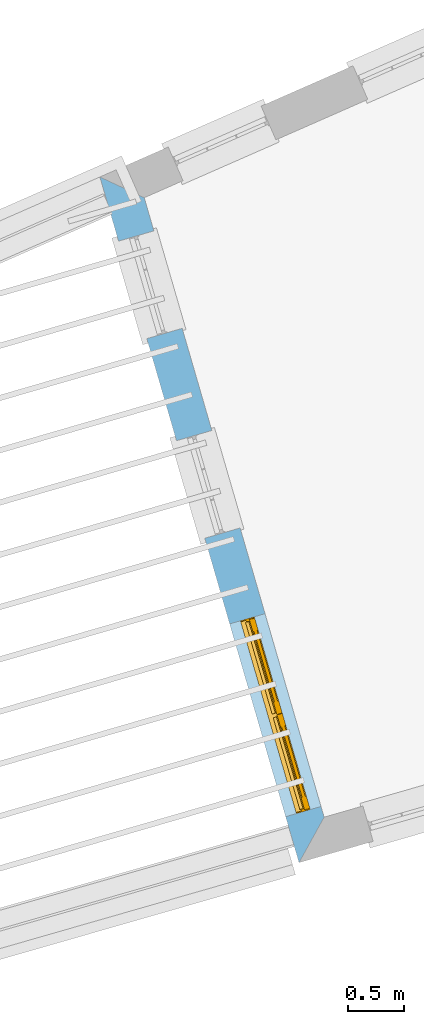
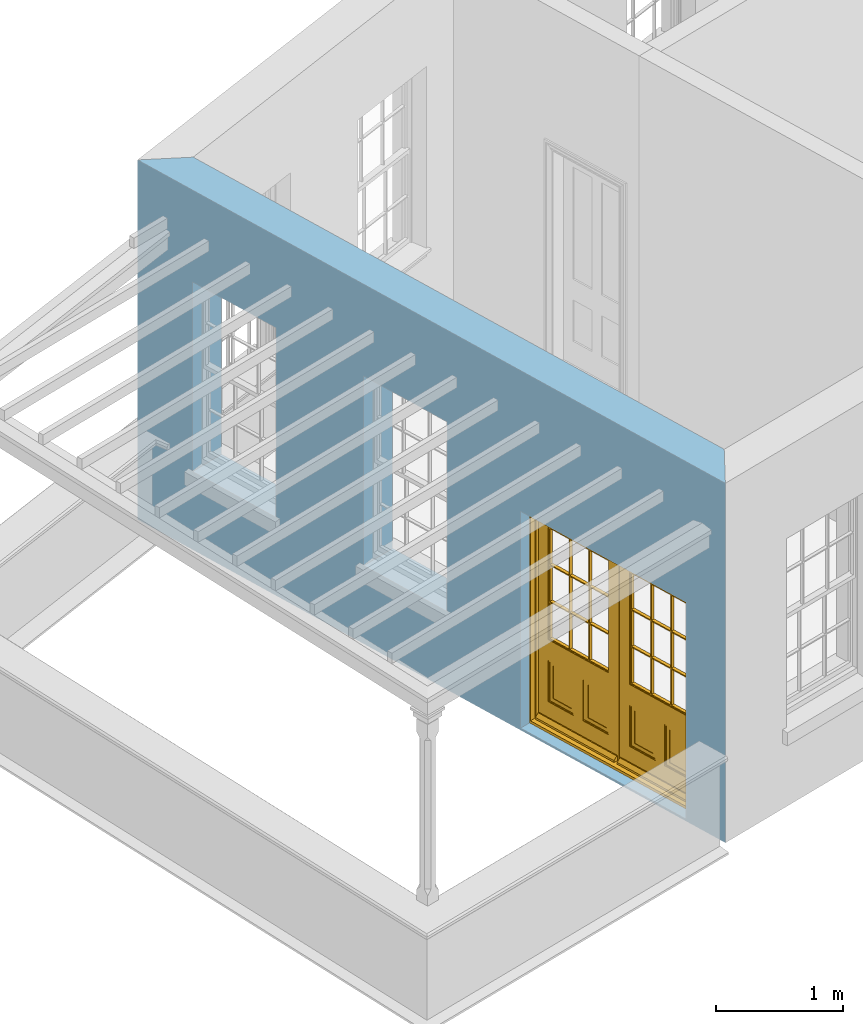
# One storey, part 3 of 11: 1 door, 3 openings, plus 1 element that does not belong to this part.
"""IFC2X3 building model written with IfcOpenShell, lengths in metres."""

import ifcopenshell
import ifcopenshell.guid

model = None  # the IFC model being written
_history = None  # IfcOwnerHistory: only IFC2X3 demands one
_inside = {}  # id of a spatial element -> (the spatial element, [elements in it])
_under = {}  # id of a project, library or spatial element -> (it, [spatial elements below it])
_declared = {}  # id of a project -> (the project, [libraries it declares])
_typed = {}  # id of a type object -> (the type object, [elements of that type])
_made_of = {}  # id of a material, layer set ... -> (it, [elements and type objects made of it])


def new_model(schema):
    """Start an empty IFC model of exactly this schema.

    Asked for "IFC4X3", IfcOpenShell would pick the latest addendum, in which some entities
    have other attributes; the version numbers below select the first issue.
    IFC2X3 requires an IfcOwnerHistory on every rooted entity: one is made here for all.
    """
    global model, _history
    if schema == "IFC4X3":
        model = ifcopenshell.file(schema_version=(4, 3, 0, 0))
    else:
        model = ifcopenshell.file(schema=schema)
    _inside.clear()
    _under.clear()
    _declared.clear()
    _typed.clear()
    _made_of.clear()
    _history = None
    if model.schema == "IFC2X3":
        org = make("IfcOrganization", Name="unknown")
        user = make(
            "IfcPersonAndOrganization",
            ThePerson=make("IfcPerson", FamilyName="unknown"),
            TheOrganization=org,
        )
        app = make(
            "IfcApplication",
            ApplicationDeveloper=org,
            Version="unknown",
            ApplicationFullName="unknown",
            ApplicationIdentifier="unknown",
        )
        _history = make(
            "IfcOwnerHistory",
            OwningUser=user,
            OwningApplication=app,
            ChangeAction="ADDED",
            CreationDate=0,
        )
    return model


def make(cls, **values):
    """One entity of the class cls with the attributes given. An attribute that is None is left unset."""
    return model.create_entity(
        cls, **{name: value for name, value in values.items() if value is not None}
    )


def rooted(cls, **values):
    """An entity with a GlobalId (a new one), such as an element, a storey or a relation."""
    return make(cls, GlobalId=ifcopenshell.guid.new(), OwnerHistory=_history, **values)


def si_unit(unit_type, name, prefix=None):
    """IfcSIUnit, for example si_unit("LENGTHUNIT", "METRE", prefix="MILLI")."""
    return make("IfcSIUnit", UnitType=unit_type, Prefix=prefix, Name=name)


def assignment(units):
    """IfcUnitAssignment: the units of a project."""
    return None if units is None else make("IfcUnitAssignment", Units=units)


def point(xyz):
    """IfcCartesianPoint."""
    return None if xyz is None else make("IfcCartesianPoint", Coordinates=xyz)


def direction(xyz):
    """IfcDirection."""
    return None if xyz is None else make("IfcDirection", DirectionRatios=xyz)


def frame(location, z_axis=None, x_axis=None):
    """IfcAxis2Placement3D, a coordinate frame: its origin and axes. An axis left out is left unset."""
    return make(
        "IfcAxis2Placement3D",
        Location=point(location),
        Axis=direction(z_axis),
        RefDirection=direction(x_axis),
    )


def origin():
    """The frame at (0, 0, 0) with its axes left unset."""
    return frame((0.0, 0.0, 0.0))


def place(relative_to, where):
    """IfcLocalPlacement: puts the frame where relative to a parent placement (None: the world)."""
    return make(
        "IfcLocalPlacement", PlacementRelTo=relative_to, RelativePlacement=where
    )


def context(
    kind, dimensions, precision=None, world=None, true_north=None, identifier=None
):
    """IfcGeometricRepresentationContext, for example the 3D "Model" context."""
    return make(
        "IfcGeometricRepresentationContext",
        ContextIdentifier=identifier,
        ContextType=kind,
        CoordinateSpaceDimension=dimensions,
        Precision=precision,
        WorldCoordinateSystem=world,
        TrueNorth=true_north,
    )


def subcontext(parent, identifier, kind, view, scale=None):
    """IfcGeometricRepresentationSubContext, for example "Body" below "Model"."""
    return make(
        "IfcGeometricRepresentationSubContext",
        ContextIdentifier=identifier,
        ContextType=kind,
        ParentContext=parent,
        TargetScale=scale,
        TargetView=view,
    )


def project(units=None, contexts=None):
    """IfcProject with its units and contexts."""
    return rooted(
        "IfcProject",
        Name="project",
        RepresentationContexts=contexts,
        UnitsInContext=assignment(units),
    )


def spatial(cls, under=None, at=None, **own):
    """A site, building, storey or space (cls), placed at a placement, below another one or the project."""
    s = rooted(cls, ObjectPlacement=at, **own)
    if under is not None:
        _under.setdefault(under.id(), (under, []))[1].append(s)
    return s


def polyline(points):
    """IfcPolyline through the points."""
    return make("IfcPolyline", Points=[point(p) for p in points])


def outline(outer, holes=None, kind="AREA"):
    """IfcArbitraryClosedProfileDef: a profile drawn as a closed curve; with holes, ...WithVoids."""
    if holes is None:
        return make("IfcArbitraryClosedProfileDef", ProfileType=kind, OuterCurve=outer)
    return make(
        "IfcArbitraryProfileDefWithVoids",
        ProfileType=kind,
        OuterCurve=outer,
        InnerCurves=holes,
    )


def extrude(swept, where, along, depth):
    """IfcExtrudedAreaSolid: the profile swept, set in the frame where, extruded along a direction by depth."""
    return make(
        "IfcExtrudedAreaSolid",
        SweptArea=swept,
        Position=where,
        ExtrudedDirection=direction(along),
        Depth=depth,
    )


def faces_of(points, faces, orient=None, outer=None):
    """IfcFace entities. A face is a list of loops; a loop is a list of indices into points, from 0.

    orient and outer hold one flag for each loop. By default every Orientation is true, the
    first loop of a face is its IfcFaceOuterBound and the others are IfcFaceBound.
    """
    made = []
    for i, loops in enumerate(faces):
        bounds = []
        for j, loop in enumerate(loops):
            is_outer = j == 0 if outer is None else outer[i][j]
            bounds.append(
                make(
                    "IfcFaceOuterBound" if is_outer else "IfcFaceBound",
                    Bound=make("IfcPolyLoop", Polygon=[points[k] for k in loop]),
                    Orientation=True if orient is None else orient[i][j],
                )
            )
        made.append(make("IfcFace", Bounds=bounds))
    return made


def faceted_brep(points, faces, orient=None, outer=None, voids=None):
    """IfcFacetedBrep: a solid bounded by flat faces; with voids (closed shells), ...WithVoids."""
    shared = [point(p) for p in points]
    hull = make("IfcClosedShell", CfsFaces=faces_of(shared, faces, orient, outer))
    if voids is None:
        return make("IfcFacetedBrep", Outer=hull)
    return make(
        "IfcFacetedBrepWithVoids",
        Outer=hull,
        Voids=[
            make(cls, CfsFaces=faces_of(shared, fs, o, b)) for cls, fs, o, b in voids
        ],
    )


def shape(context_of_items, identifier, shape_type, items):
    """IfcShapeRepresentation: the items that make up one representation, for example the "Body"."""
    return make(
        "IfcShapeRepresentation",
        ContextOfItems=context_of_items,
        RepresentationIdentifier=identifier,
        RepresentationType=shape_type,
        Items=items,
    )


def material(Name=None, Category=None):
    """IfcMaterial."""
    return make("IfcMaterial", Name=Name, Category=Category)


def layer(
    of_material, thickness, ventilated=None, Name=None, Category=None, Priority=None
):
    """IfcMaterialLayer: one layer of a wall or slab, of a material (None: an air gap)."""
    return make(
        "IfcMaterialLayer",
        Material=of_material,
        LayerThickness=thickness,
        IsVentilated=ventilated,
        Name=Name,
        Category=Category,
        Priority=Priority,
    )


def layer_set(layers, Name=None):
    """IfcMaterialLayerSet."""
    return make("IfcMaterialLayerSet", MaterialLayers=layers, LayerSetName=Name)


def layer_usage(for_layer_set, set_direction, sense, offset, extent=None):
    """IfcMaterialLayerSetUsage: how a layer set lies in its element."""
    return make(
        "IfcMaterialLayerSetUsage",
        ForLayerSet=for_layer_set,
        LayerSetDirection=set_direction,
        DirectionSense=sense,
        OffsetFromReferenceLine=offset,
        ReferenceExtent=extent,
    )


def made_of(thing, what):
    """Note that an element or type object is made of a material, layer set ...; save() writes the relation."""
    if what is not None:
        _made_of.setdefault(what.id(), (what, []))[1].append(thing)
    return thing


def element(
    cls,
    number,
    at=None,
    inside=None,
    cuts=None,
    type_object=None,
    material=None,
    context=None,
    identifier="Body",
    shape_type=None,
    held_by="IfcProductDefinitionShape",
    body=None,
    shapes=None,
    **own,
):
    """One element of the class cls, such as IfcWall. Its Tag is "e" and its number.

    at: its placement. inside: the storey or other place that contains it. cuts: it is an
    opening in that element (IfcRelVoidsElement). A single representation is given by context,
    identifier, shape_type and body (its items); several are given by shapes. held_by: the class
    of the entity that holds the representations. save() writes the other relations.
    """
    e = rooted(cls, Tag="e%d" % number, ObjectPlacement=at, **own)
    if body is not None:
        shapes = [shape(context, identifier, shape_type, body)]
    if shapes is not None:
        e.Representation = make(held_by, Representations=shapes)
    if inside is not None:
        _inside.setdefault(inside.id(), (inside, []))[1].append(e)
    if cuts is not None:
        rooted(
            "IfcRelVoidsElement", RelatingBuildingElement=cuts, RelatedOpeningElement=e
        )
    if type_object is not None:
        _typed.setdefault(type_object.id(), (type_object, []))[1].append(e)
    return made_of(e, material)


def fill(opening, filler):
    """IfcRelFillsElement: the door or window that sits in an opening."""
    return rooted(
        "IfcRelFillsElement",
        RelatingOpeningElement=opening,
        RelatedBuildingElement=filler,
    )


def aggregate(whole, parts):
    """IfcRelAggregates: a whole, such as a stair, and the parts it consists of."""
    return rooted("IfcRelAggregates", RelatingObject=whole, RelatedObjects=parts)


def save(model, path):
    """Write the relations noted so far, then the file.

    IfcRelAggregates (storeys below a building ...), IfcRelContainedInSpatialStructure (elements
    in a storey), IfcRelDefinesByType, IfcRelAssociatesMaterial and IfcRelDeclares: one each for
    every whole, place, type object, material and project.
    """
    for whole, parts in _under.values():
        aggregate(whole, parts)
    for where, things in _inside.values():
        rooted(
            "IfcRelContainedInSpatialStructure",
            RelatedElements=things,
            RelatingStructure=where,
        )
    for kind, things in _typed.values():
        rooted("IfcRelDefinesByType", RelatedObjects=things, RelatingType=kind)
    for what, things in _made_of.values():
        rooted("IfcRelAssociatesMaterial", RelatedObjects=things, RelatingMaterial=what)
    for by, libraries in _declared.values():
        rooted("IfcRelDeclares", RelatingContext=by, RelatedDefinitions=libraries)
    model.write(path)


model = new_model("IFC2X3")

# Units and contexts
model_context = context("Model", 3, world=origin())
body_context = subcontext(model_context, "Body", "Model", "MODEL_VIEW")
ifc_project = project(units=[si_unit("PLANEANGLEUNIT", "RADIAN"), si_unit("MASSUNIT", "GRAM", prefix="KILO"), si_unit("FORCEUNIT", "NEWTON", prefix="KILO"), si_unit("LENGTHUNIT", "METRE")], contexts=[model_context])

# Site, building, storey
site_placement = place(None, origin())
site = spatial("IfcSite", under=ifc_project, at=site_placement, CompositionType="ELEMENT")
building_placement = place(None, origin())
building = spatial("IfcBuilding", under=site, at=building_placement, Name="Building plot-15", CompositionType="ELEMENT")
storey_placement = place(None, frame((0.0, 0.0, 7.6)))
storey = spatial("IfcBuildingStorey", under=building, at=storey_placement, Name="Floor 1", CompositionType="ELEMENT", Elevation=7.6)

# Wall, openings, door
ifc_material = material(Name="Masonry")
ifc_layer = layer(ifc_material, 0.33, ventilated=False)
ifc_layer_set = layer_set([ifc_layer], Name="My Wall")
ifc_layer_usage = layer_usage(ifc_layer_set, "AXIS2", "NEGATIVE", 0.08)
wall_placement = place(storey_placement, origin())
wall = element("IfcWallStandardCase", 1, at=wall_placement, inside=storey, material=ifc_layer_usage, Name="exterior", context=body_context, shape_type="SweptSolid", body=[
    extrude(outline(polyline([(85.6873979783644, 56.0228656256528), (85.2898260322487, 56.2086132391335), (87.0751399602823, 50.0606585087336), (87.3002897494389, 50.4686684405552), (85.6873979783644, 56.0228656256528)])), origin(), (0.0, 0.0, 1.0), 3.45),
])
opening_1_placement = place(storey_placement, frame((0.0, 0.0, 0.75)))
element("IfcOpeningElement", 2, at=opening_1_placement, cuts=wall, Name="Opening", ObjectType="Opening", context=body_context, shape_type="SweptSolid", body=[
    extrude(outline(polyline([(85.4569058524119, 55.6332527075221), (85.7106786931988, 54.7593537744188), (86.0275870975109, 54.8513812881108), (85.773814256724, 55.725280221214), (85.4569058524119, 55.6332527075221)])), origin(), (0.0, 0.0, 1.0), 1.82),
])
opening_2_placement = place(storey_placement, frame((0.0, 0.0, 0.75)))
element("IfcOpeningElement", 3, at=opening_2_placement, cuts=wall, Name="Opening", ObjectType="Opening", context=body_context, shape_type="SweptSolid", body=[
    extrude(outline(polyline([(85.9765909320635, 53.8436512858375), (86.2303637728504, 52.9697523527342), (86.5472721771625, 53.0617798664262), (86.2934993363756, 53.9356787995294), (85.9765909320635, 53.8436512858375)])), origin(), (0.0, 0.0, 1.0), 1.82),
])
opening_3_placement = place(storey_placement, frame((0.0, 0.0, 0.0199999999999996)))
opening_3 = element("IfcOpeningElement", 4, at=opening_3_placement, cuts=wall, Name="Opening", ObjectType="Opening", context=body_context, shape_type="SweptSolid", body=[
    extrude(outline(polyline([(86.45346077574, 52.2014895544017), (86.9554290322415, 50.4728982581536), (87.2723374365537, 50.5649257718456), (86.7703691800521, 52.2935170680937), (86.45346077574, 52.2014895544017)])), origin(), (0.0, 0.0, 1.0), 2.08),
])
door_placement = place(storey_placement, frame((86.6935429002189, 52.2712073678047, 0.0199999999999996), z_axis=(0.0, 0.0, 1.0), x_axis=(0.501968256501584, -1.72859129624812, 0.0)))
door = element("IfcDoor", 5, at=door_placement, inside=storey, Name="living outside door", OverallHeight=2.08, OverallWidth=1.8, context=body_context, shape_type="Brep", held_by="IfcProductRepresentation", body=[
    faceted_brep([(0.545, -0.055, 0.265), (0.745, -0.055, 0.265), (0.745, -0.05, 0.265), (0.545, -0.05, 0.265), (0.745, -0.05, 0.58), (0.545, -0.05, 0.58), (0.545, -0.055, 0.58), (0.515, -0.06, 0.235), (0.775, -0.06, 0.235), (0.745, -0.055, 0.58), (0.515, -0.06, 0.61), (0.515, -0.065, 0.235), (0.775, -0.065, 0.235), (0.775, -0.06, 0.61), (0.515, -0.065, 0.61), (0.785, -0.065, 0.225), (0.505, -0.065, 0.225), (0.775, -0.065, 0.61), (0.505, -0.065, 0.62), (0.785, -0.065, 0.62), (0.505, -0.07, 0.225), (0.785, -0.07, 0.225), (0.505, -0.07, 0.62), (0.785, -0.07, 0.62), (0.883, -0.07, 0.075), (0.898, -0.07, 0.075), (0.405, -0.07, 0.62), (0.405, -0.07, 0.225), (0.027, -0.07, 0.075), (0.785, -0.07, 0.82), (0.125, -0.07, 0.82), (0.405, -0.065, 0.62), (0.405, -0.065, 0.225), (0.898, -0.07, 2.068), (0.027, -0.08, 0.075), (0.883, -0.08, 0.075), (0.125, -0.07, 0.225), (0.012, -0.07, 0.075), (0.785, -0.06, 0.82), (0.125, -0.06, 0.82), (0.125, -0.07, 0.62), (0.125, -0.065, 0.62), (0.395, -0.065, 0.61), (0.395, -0.065, 0.235), (0.125, -0.065, 0.225), (0.785, -0.07, 1.895), (0.027, -0.11, 0.045), (0.883, -0.11, 0.045), (0.558333, -0.06, 0.83), (0.351667, -0.06, 0.83), (0.125, -0.07, 1.895), (0.125, -0.06, 1.895), (0.785, -0.06, 1.895), (0.012, -0.07, 2.068), (0.135, -0.065, 0.61), (0.395, -0.06, 0.61), (0.395, -0.06, 0.235), (0.135, -0.065, 0.235), (0.027, -0.11, 0.027), (0.883, -0.11, 0.027), (0.568333, -0.06, 0.83), (0.558333, -0.03, 0.83), (0.351667, -0.03, 0.83), (0.341667, -0.06, 0.83), (0.135, -0.06, 1.185), (0.135, -0.06, 1.53), (0.775, -0.06, 1.53), (0.775, -0.06, 1.185), (0.135, -0.06, 0.61), (0.365, -0.055, 0.58), (0.365, -0.055, 0.265), (0.135, -0.06, 0.235), (0.568333, -0.06, 1.175), (0.558333, -0.06, 1.175), (0.775, -0.06, 0.83), (0.558333, -0.03, 1.175), (0.785, -0.03, 0.82), (0.125, -0.03, 0.82), (0.351667, -0.03, 1.175), (0.351667, -0.06, 1.175), (0.341667, -0.06, 1.175), (0.135, -0.06, 0.83), (0.135, -0.06, 1.175), (0.135, -0.03, 1.185), (0.135, -0.03, 1.53), (0.135, -0.06, 1.54), (0.351667, -0.06, 1.885), (0.558333, -0.06, 1.885), (0.775, -0.03, 1.53), (0.775, -0.03, 1.185), (0.775, -0.06, 1.175), (0.775, -0.06, 1.54), (0.165, -0.055, 0.58), (0.365, -0.05, 0.58), (0.365, -0.05, 0.265), (0.165, -0.055, 0.265), (0.568333, -0.03, 0.83), (0.568333, -0.03, 1.175), (0.568333, -0.06, 1.185), (0.558333, -0.06, 1.185), (0.775, -0.03, 0.83), (0.785, -0.02, 0.82), (0.125, -0.02, 0.82), (0.341667, -0.03, 0.83), (0.341667, -0.03, 1.175), (0.351667, -0.06, 1.185), (0.341667, -0.06, 1.185), (0.135, -0.03, 0.83), (0.341667, -0.03, 1.185), (0.125, -0.03, 1.895), (0.341667, -0.03, 1.53), (0.341667, -0.06, 1.53), (0.135, -0.06, 1.885), (0.341667, -0.06, 1.54), (0.341667, -0.06, 1.885), (0.558333, -0.03, 1.885), (0.351667, -0.03, 1.885), (0.568333, -0.06, 1.885), (0.785, -0.03, 1.895), (0.568333, -0.03, 1.185), (0.568333, -0.06, 1.53), (0.568333, -0.03, 1.53), (0.568333, -0.06, 1.54), (0.775, -0.06, 1.885), (0.165, -0.05, 0.58), (0.165, -0.05, 0.265), (0.775, -0.03, 1.175), (0.558333, -0.06, 1.53), (0.351667, -0.03, 1.185), (0.558333, -0.03, 1.185), (0.505, -0.02, 0.62), (0.405, -0.02, 0.62), (0.125, -0.02, 1.895), (0.785, -0.02, 1.895), (0.351667, -0.06, 1.53), (0.135, -0.03, 1.175), (0.135, -0.03, 1.54), (0.341667, -0.03, 1.54), (0.135, -0.03, 1.885), (0.351667, -0.06, 1.54), (0.558333, -0.03, 1.54), (0.558333, -0.06, 1.54), (0.351667, -0.03, 1.54), (0.775, -0.03, 1.54), (0.568333, -0.03, 1.54), (0.775, -0.03, 1.885), (0.558333, -0.03, 1.53), (0.405, -0.02, 0.225), (0.505, -0.02, 0.225), (0.125, -0.02, 0.62), (0.785, -0.02, 0.62), (0.012, -0.02, 2.068), (0.898, -0.02, 2.068), (0.351667, -0.03, 1.53), (0.341667, -0.03, 1.885), (0.568333, -0.03, 1.885), (0.405, -0.025, 0.225), (0.405, -0.025, 0.62), (0.505, -0.025, 0.62), (0.505, -0.025, 0.225), (0.898, -0.02, 0.027), (0.012, -0.02, 0.027), (0.125, -0.025, 0.62), (0.785, -0.025, 0.62), (0.395, -0.025, 0.235), (0.395, -0.025, 0.61), (0.125, -0.02, 0.225), (0.125, -0.025, 0.225), (0.515, -0.025, 0.61), (0.515, -0.025, 0.235), (0.785, -0.02, 0.225), (0.785, -0.025, 0.225), (0.135, -0.025, 0.61), (0.775, -0.025, 0.61), (0.135, -0.025, 0.235), (0.395, -0.03, 0.235), (0.395, -0.03, 0.61), (0.515, -0.03, 0.61), (0.515, -0.03, 0.235), (0.775, -0.025, 0.235), (0.135, -0.03, 0.61), (0.775, -0.03, 0.61), (0.135, -0.03, 0.235), (0.365, -0.035, 0.265), (0.365, -0.035, 0.58), (0.545, -0.035, 0.58), (0.545, -0.035, 0.265), (0.775, -0.03, 0.235), (0.165, -0.035, 0.58), (0.745, -0.035, 0.58), (0.165, -0.035, 0.265), (0.365, -0.04, 0.58), (0.365, -0.04, 0.265), (0.545, -0.04, 0.58), (0.545, -0.04, 0.265), (0.745, -0.035, 0.265), (0.165, -0.04, 0.58), (0.745, -0.04, 0.58), (0.165, -0.04, 0.265), (0.745, -0.04, 0.265), (1.775, -0.072, 0.025), (0.025, -0.072, 0.025), (0.025, -0.1, 0.025), (1.775, -0.1, 0.025), (1.79, -0.02, 0.025), (0.01, -0.02, 0.025), (1.79, -0.072, 0.025), (1.8, -0.02, 0.0), (0.0, -0.02, 0.0), (0.01, -0.072, 0.025), (1.79, -0.072, 2.07), (1.79, -0.02, 2.07), (1.775, -0.072, 2.055), (1.8, -0.02, 2.08), (0.01, -0.02, 2.07), (0.0, -0.02, 2.08), (0.01, -0.072, 2.07), (0.025, -0.072, 2.055), (0.0, -0.15, 2.08), (1.8, -0.15, 2.08), (0.01, -0.15, 2.07), (1.79, -0.15, 2.07), (0.01, -0.1, 2.07), (1.79, -0.1, 2.07), (0.0, -0.15, 0.0), (1.8, -0.15, 0.0), (0.01, -0.15, 0.025), (1.79, -0.15, 0.025), (0.01, -0.1, 0.025), (0.025, -0.1, 2.055), (1.79, -0.1, 0.025), (1.775, -0.1, 2.055), (0.898, -0.07, 0.027), (0.012, -0.07, 0.027), (0.883, -0.07, 0.027), (0.027, -0.07, 0.027), (1.435, -0.055, 0.265), (1.635, -0.055, 0.265), (1.635, -0.05, 0.265), (1.435, -0.05, 0.265), (1.635, -0.05, 0.58), (1.435, -0.05, 0.58), (1.435, -0.055, 0.58), (1.405, -0.06, 0.235), (1.665, -0.06, 0.235), (1.635, -0.055, 0.58), (1.405, -0.06, 0.61), (1.405, -0.065, 0.235), (1.665, -0.065, 0.235), (1.665, -0.06, 0.61), (1.405, -0.065, 0.61), (1.675, -0.065, 0.225), (1.395, -0.065, 0.225), (1.665, -0.065, 0.61), (1.395, -0.065, 0.62), (1.675, -0.065, 0.62), (1.395, -0.07, 0.225), (1.675, -0.07, 0.225), (1.395, -0.07, 0.62), (1.675, -0.07, 0.62), (1.773, -0.07, 0.075), (1.788, -0.07, 0.075), (1.295, -0.07, 0.62), (1.295, -0.07, 0.225), (0.917, -0.07, 0.075), (1.675, -0.07, 0.82), (1.015, -0.07, 0.82), (1.295, -0.065, 0.62), (1.295, -0.065, 0.225), (1.788, -0.07, 2.068), (0.917, -0.08, 0.075), (1.773, -0.08, 0.075), (1.015, -0.07, 0.225), (0.902, -0.07, 0.075), (1.675, -0.06, 0.82), (1.015, -0.06, 0.82), (1.015, -0.07, 0.62), (1.015, -0.065, 0.62), (1.285, -0.065, 0.61), (1.285, -0.065, 0.235), (1.015, -0.065, 0.225), (1.675, -0.07, 1.895), (0.917, -0.11, 0.045), (1.773, -0.11, 0.045), (1.448333, -0.06, 0.83), (1.241667, -0.06, 0.83), (1.015, -0.07, 1.895), (1.015, -0.06, 1.895), (1.675, -0.06, 1.895), (0.902, -0.07, 2.068), (1.025, -0.065, 0.61), (1.285, -0.06, 0.61), (1.285, -0.06, 0.235), (1.025, -0.065, 0.235), (0.917, -0.11, 0.027), (1.773, -0.11, 0.027), (1.458333, -0.06, 0.83), (1.448333, -0.03, 0.83), (1.241667, -0.03, 0.83), (1.231667, -0.06, 0.83), (1.025, -0.06, 1.185), (1.025, -0.06, 1.53), (1.665, -0.06, 1.53), (1.665, -0.06, 1.185), (1.025, -0.06, 0.61), (1.255, -0.055, 0.58), (1.255, -0.055, 0.265), (1.025, -0.06, 0.235), (1.458333, -0.06, 1.175), (1.448333, -0.06, 1.175), (1.665, -0.06, 0.83), (1.448333, -0.03, 1.175), (1.675, -0.03, 0.82), (1.015, -0.03, 0.82), (1.241667, -0.03, 1.175), (1.241667, -0.06, 1.175), (1.231667, -0.06, 1.175), (1.025, -0.06, 0.83), (1.025, -0.06, 1.175), (1.025, -0.03, 1.185), (1.025, -0.03, 1.53), (1.025, -0.06, 1.54), (1.241667, -0.06, 1.885), (1.448333, -0.06, 1.885), (1.665, -0.03, 1.53), (1.665, -0.03, 1.185), (1.665, -0.06, 1.175), (1.665, -0.06, 1.54), (1.055, -0.055, 0.58), (1.255, -0.05, 0.58), (1.255, -0.05, 0.265), (1.055, -0.055, 0.265), (1.458333, -0.03, 0.83), (1.458333, -0.03, 1.175), (1.458333, -0.06, 1.185), (1.448333, -0.06, 1.185), (1.665, -0.03, 0.83), (1.675, -0.02, 0.82), (1.015, -0.02, 0.82), (1.231667, -0.03, 0.83), (1.231667, -0.03, 1.175), (1.241667, -0.06, 1.185), (1.231667, -0.06, 1.185), (1.025, -0.03, 0.83), (1.231667, -0.03, 1.185), (1.015, -0.03, 1.895), (1.231667, -0.03, 1.53), (1.231667, -0.06, 1.53), (1.025, -0.06, 1.885), (1.231667, -0.06, 1.54), (1.231667, -0.06, 1.885), (1.448333, -0.03, 1.885), (1.241667, -0.03, 1.885), (1.458333, -0.06, 1.885), (1.675, -0.03, 1.895), (1.458333, -0.03, 1.185), (1.458333, -0.06, 1.53), (1.458333, -0.03, 1.53), (1.458333, -0.06, 1.54), (1.665, -0.06, 1.885), (1.055, -0.05, 0.58), (1.055, -0.05, 0.265), (1.665, -0.03, 1.175), (1.448333, -0.06, 1.53), (1.241667, -0.03, 1.185), (1.448333, -0.03, 1.185), (1.395, -0.02, 0.62), (1.295, -0.02, 0.62), (1.015, -0.02, 1.895), (1.675, -0.02, 1.895), (1.241667, -0.06, 1.53), (1.025, -0.03, 1.175), (1.025, -0.03, 1.54), (1.231667, -0.03, 1.54), (1.025, -0.03, 1.885), (1.241667, -0.06, 1.54), (1.448333, -0.03, 1.54), (1.448333, -0.06, 1.54), (1.241667, -0.03, 1.54), (1.665, -0.03, 1.54), (1.458333, -0.03, 1.54), (1.665, -0.03, 1.885), (1.448333, -0.03, 1.53), (1.295, -0.02, 0.225), (1.395, -0.02, 0.225), (1.015, -0.02, 0.62), (1.675, -0.02, 0.62), (0.902, -0.02, 2.068), (1.788, -0.02, 2.068), (1.241667, -0.03, 1.53), (1.231667, -0.03, 1.885), (1.458333, -0.03, 1.885), (1.295, -0.025, 0.225), (1.295, -0.025, 0.62), (1.395, -0.025, 0.62), (1.395, -0.025, 0.225), (1.788, -0.02, 0.027), (0.902, -0.02, 0.027), (1.015, -0.025, 0.62), (1.675, -0.025, 0.62), (1.285, -0.025, 0.235), (1.285, -0.025, 0.61), (1.015, -0.02, 0.225), (1.015, -0.025, 0.225), (1.405, -0.025, 0.61), (1.405, -0.025, 0.235), (1.675, -0.02, 0.225), (1.675, -0.025, 0.225), (1.025, -0.025, 0.61), (1.665, -0.025, 0.61), (1.025, -0.025, 0.235), (1.285, -0.03, 0.235), (1.285, -0.03, 0.61), (1.405, -0.03, 0.61), (1.405, -0.03, 0.235), (1.665, -0.025, 0.235), (1.025, -0.03, 0.61), (1.665, -0.03, 0.61), (1.025, -0.03, 0.235), (1.255, -0.035, 0.265), (1.255, -0.035, 0.58), (1.435, -0.035, 0.58), (1.435, -0.035, 0.265), (1.665, -0.03, 0.235), (1.055, -0.035, 0.58), (1.635, -0.035, 0.58), (1.055, -0.035, 0.265), (1.255, -0.04, 0.58), (1.255, -0.04, 0.265), (1.435, -0.04, 0.58), (1.435, -0.04, 0.265), (1.635, -0.035, 0.265), (1.055, -0.04, 0.58), (1.635, -0.04, 0.58), (1.055, -0.04, 0.265), (1.635, -0.04, 0.265), (1.788, -0.07, 0.027), (0.902, -0.07, 0.027), (1.773, -0.07, 0.027), (0.917, -0.07, 0.027)], [[[0, 1, 2, 3]], [[2, 4, 5, 3]], [[0, 3, 5, 6]], [[1, 0, 7, 8]], [[9, 4, 2, 1]], [[9, 6, 5, 4]], [[0, 6, 10, 7]], [[8, 7, 11, 12]], [[8, 13, 9, 1]], [[13, 10, 6, 9]], [[7, 10, 14, 11]], [[15, 12, 11, 16]], [[12, 17, 13, 8]], [[17, 14, 10, 13]], [[18, 16, 11, 14]], [[15, 19, 17, 12]], [[15, 16, 20, 21]], [[14, 17, 19, 18]], [[16, 18, 22, 20]], [[21, 23, 19, 15]], [[24, 25, 21, 20]], [[23, 22, 18, 19]], [[20, 22, 26, 27]], [[23, 21, 25]], [[28, 24, 20, 27]], [[22, 23, 29]], [[29, 30, 26, 22]], [[27, 26, 31, 32]], [[23, 25, 33, 29]], [[34, 35, 24, 28]], [[28, 27, 36, 37]], [[38, 39, 30, 29]], [[26, 30, 40]], [[26, 40, 41, 31]], [[42, 43, 32, 31]], [[32, 44, 36, 27]], [[33, 45, 29]], [[46, 47, 35, 34]], [[36, 40, 37]], [[39, 38, 48, 49]], [[50, 30, 39, 51]], [[29, 45, 52, 38]], [[53, 37, 40, 30]], [[44, 41, 40, 36]], [[31, 41, 54, 42]], [[43, 42, 55, 56]], [[57, 44, 32, 43]], [[50, 45, 33, 53]], [[47, 46, 58, 59]], [[60, 48, 38]], [[49, 48, 61, 62]], [[49, 63, 39]], [[50, 53, 30]], [[51, 39, 64, 65]], [[45, 50, 51, 52]], [[66, 67, 38, 52]], [[57, 54, 41, 44]], [[42, 54, 68, 55]], [[56, 55, 69, 70]], [[56, 71, 57, 43]], [[60, 72, 73, 48]], [[60, 38, 74]], [[48, 73, 75, 61]], [[76, 77, 62, 61]], [[62, 78, 79, 49]], [[49, 79, 80, 63]], [[63, 81, 39]], [[82, 64, 39]], [[65, 64, 83, 84]], [[85, 51, 65]], [[52, 51, 86, 87]], [[88, 89, 67, 66]], [[90, 38, 67]], [[91, 66, 52]], [[71, 68, 54, 57]], [[55, 68, 92, 69]], [[69, 93, 94, 70]], [[70, 95, 71, 56]], [[96, 97, 72, 60]], [[73, 72, 98, 99]], [[74, 38, 90]], [[100, 96, 60, 74]], [[75, 73, 79, 78]], [[61, 75, 97, 96]], [[101, 102, 77, 76]], [[77, 103, 62]], [[96, 76, 61]], [[103, 104, 78, 62]], [[80, 79, 105, 106]], [[63, 80, 104, 103]], [[81, 63, 103, 107]], [[81, 82, 39]], [[106, 64, 82, 80]], [[106, 108, 83, 64]], [[84, 83, 77, 109]], [[110, 111, 65, 84]], [[112, 51, 85]], [[113, 85, 65, 111]], [[114, 86, 51]], [[115, 87, 86, 116]], [[117, 52, 87]], [[118, 76, 89, 88]], [[119, 98, 67, 89]], [[120, 121, 88, 66]], [[67, 98, 72, 90]], [[91, 122, 120, 66]], [[91, 52, 123]], [[95, 92, 68, 71]], [[69, 92, 124, 93]], [[94, 93, 124, 125]], [[94, 125, 95, 70]], [[72, 97, 126, 90]], [[127, 99, 98, 120]], [[99, 105, 79, 73]], [[74, 90, 126, 100]], [[96, 100, 76]], [[128, 129, 75, 78]], [[97, 75, 129, 119]], [[130, 131, 102, 101]], [[109, 77, 102, 132]], [[133, 101, 76, 118]], [[77, 107, 103]], [[78, 104, 108, 128]], [[111, 106, 105, 134]], [[104, 80, 82, 135]], [[107, 135, 82, 81]], [[110, 108, 106, 111]], [[104, 135, 83, 108]], [[83, 135, 77]], [[136, 84, 109]], [[110, 84, 136, 137]], [[114, 51, 112]], [[85, 136, 138, 112]], [[113, 137, 136, 85]], [[111, 134, 139, 113]], [[86, 114, 113, 139]], [[140, 141, 87, 115]], [[139, 142, 116, 86]], [[109, 118, 115, 116]], [[117, 123, 52]], [[117, 87, 141, 122]], [[126, 89, 76]], [[143, 118, 88]], [[120, 98, 119, 121]], [[119, 89, 126, 97]], [[144, 143, 88, 121]], [[144, 122, 91, 143]], [[127, 120, 122, 141]], [[143, 91, 123, 145]], [[124, 92, 95, 125]], [[146, 129, 99, 127]], [[99, 129, 128, 105]], [[100, 126, 76]], [[121, 119, 129, 146]], [[147, 131, 130, 148]], [[131, 149, 102]], [[130, 101, 150]], [[102, 151, 132]], [[118, 109, 132, 133]], [[101, 133, 152]], [[107, 77, 135]], [[153, 128, 108, 110]], [[134, 105, 128, 153]], [[109, 138, 136]], [[153, 110, 137, 142]], [[154, 114, 112, 138]], [[137, 113, 114, 154]], [[141, 139, 134, 127]], [[141, 140, 142, 139]], [[144, 140, 115, 155]], [[142, 137, 154, 116]], [[155, 115, 118]], [[116, 154, 109]], [[117, 155, 145, 123]], [[122, 144, 155, 117]], [[143, 145, 118]], [[121, 146, 140, 144]], [[146, 127, 134, 153]], [[156, 157, 131, 147]], [[148, 130, 158, 159]], [[148, 160, 161, 147]], [[157, 162, 149, 131]], [[161, 151, 102, 149]], [[101, 152, 160, 150]], [[163, 158, 130, 150]], [[151, 152, 133, 132]], [[154, 138, 109]], [[142, 140, 146, 153]], [[145, 155, 118]], [[157, 156, 164, 165]], [[147, 166, 167, 156]], [[168, 169, 159, 158]], [[170, 148, 159, 171]], [[148, 170, 160]], [[166, 147, 161]], [[172, 162, 157, 165]], [[166, 149, 162, 167]], [[166, 161, 149]], [[150, 160, 170]], [[163, 173, 168, 158]], [[171, 163, 150, 170]], [[174, 164, 156, 167]], [[175, 176, 165, 164]], [[169, 168, 177, 178]], [[171, 159, 169, 179]], [[167, 162, 172, 174]], [[176, 180, 172, 165]], [[179, 173, 163, 171]], [[181, 177, 168, 173]], [[164, 174, 182, 175]], [[183, 184, 176, 175]], [[178, 177, 185, 186]], [[179, 169, 178, 187]], [[174, 172, 180, 182]], [[184, 188, 180, 176]], [[187, 181, 173, 179]], [[189, 185, 177, 181]], [[175, 182, 190, 183]], [[191, 184, 183, 192]], [[185, 193, 194, 186]], [[187, 178, 186, 195]], [[182, 180, 188, 190]], [[191, 196, 188, 184]], [[195, 189, 181, 187]], [[197, 193, 185, 189]], [[183, 190, 198, 192]], [[198, 196, 191, 192]], [[194, 193, 197, 199]], [[195, 186, 194, 199]], [[188, 196, 198, 190]], [[197, 189, 195, 199]], [[200, 201, 202, 203]], [[201, 200, 204, 205]], [[206, 204, 200]], [[204, 207, 208, 205]], [[209, 201, 205]], [[210, 211, 204, 206]], [[206, 200, 212, 210]], [[211, 213, 207, 204]], [[214, 205, 208, 215]], [[216, 217, 201, 209]], [[205, 214, 216, 209]], [[216, 214, 211, 210]], [[210, 212, 217, 216]], [[214, 215, 213, 211]], [[218, 219, 213, 215]], [[219, 218, 220, 221]], [[221, 220, 222, 223]], [[215, 208, 224, 218]], [[225, 224, 208, 207]], [[224, 226, 220, 218]], [[224, 225, 227, 226]], [[219, 225, 207, 213]], [[228, 222, 220, 226]], [[219, 221, 227, 225]], [[226, 227, 203, 202]], [[202, 229, 222, 228]], [[228, 226, 202]], [[227, 221, 223, 230]], [[230, 203, 227]], [[217, 229, 202, 201]], [[231, 223, 222, 229]], [[230, 223, 231, 203]], [[231, 229, 217, 212]], [[212, 200, 203, 231]], [[33, 152, 151, 53]], [[25, 160, 152, 33]], [[161, 37, 53, 151]], [[232, 160, 25]], [[161, 233, 37]], [[160, 232, 234]], [[24, 234, 232, 25]], [[233, 161, 235]], [[37, 233, 235, 28]], [[161, 160, 234, 235]], [[35, 47, 234, 24]], [[28, 235, 46, 34]], [[58, 235, 234, 59]], [[59, 234, 47]], [[58, 46, 235]], [[236, 237, 238, 239]], [[238, 240, 241, 239]], [[236, 239, 241, 242]], [[237, 236, 243, 244]], [[245, 240, 238, 237]], [[245, 242, 241, 240]], [[236, 242, 246, 243]], [[244, 243, 247, 248]], [[244, 249, 245, 237]], [[249, 246, 242, 245]], [[243, 246, 250, 247]], [[251, 248, 247, 252]], [[248, 253, 249, 244]], [[253, 250, 246, 249]], [[254, 252, 247, 250]], [[251, 255, 253, 248]], [[251, 252, 256, 257]], [[250, 253, 255, 254]], [[252, 254, 258, 256]], [[257, 259, 255, 251]], [[260, 261, 257, 256]], [[259, 258, 254, 255]], [[256, 258, 262, 263]], [[259, 257, 261]], [[264, 260, 256, 263]], [[258, 259, 265]], [[265, 266, 262, 258]], [[263, 262, 267, 268]], [[259, 261, 269, 265]], [[270, 271, 260, 264]], [[264, 263, 272, 273]], [[274, 275, 266, 265]], [[262, 266, 276]], [[262, 276, 277, 267]], [[278, 279, 268, 267]], [[268, 280, 272, 263]], [[269, 281, 265]], [[282, 283, 271, 270]], [[272, 276, 273]], [[275, 274, 284, 285]], [[286, 266, 275, 287]], [[265, 281, 288, 274]], [[289, 273, 276, 266]], [[280, 277, 276, 272]], [[267, 277, 290, 278]], [[279, 278, 291, 292]], [[293, 280, 268, 279]], [[286, 281, 269, 289]], [[283, 282, 294, 295]], [[296, 284, 274]], [[285, 284, 297, 298]], [[285, 299, 275]], [[286, 289, 266]], [[287, 275, 300, 301]], [[281, 286, 287, 288]], [[302, 303, 274, 288]], [[293, 290, 277, 280]], [[278, 290, 304, 291]], [[292, 291, 305, 306]], [[292, 307, 293, 279]], [[296, 308, 309, 284]], [[296, 274, 310]], [[284, 309, 311, 297]], [[312, 313, 298, 297]], [[298, 314, 315, 285]], [[285, 315, 316, 299]], [[299, 317, 275]], [[318, 300, 275]], [[301, 300, 319, 320]], [[321, 287, 301]], [[288, 287, 322, 323]], [[324, 325, 303, 302]], [[326, 274, 303]], [[327, 302, 288]], [[307, 304, 290, 293]], [[291, 304, 328, 305]], [[305, 329, 330, 306]], [[306, 331, 307, 292]], [[332, 333, 308, 296]], [[309, 308, 334, 335]], [[310, 274, 326]], [[336, 332, 296, 310]], [[311, 309, 315, 314]], [[297, 311, 333, 332]], [[337, 338, 313, 312]], [[313, 339, 298]], [[332, 312, 297]], [[339, 340, 314, 298]], [[316, 315, 341, 342]], [[299, 316, 340, 339]], [[317, 299, 339, 343]], [[317, 318, 275]], [[342, 300, 318, 316]], [[342, 344, 319, 300]], [[320, 319, 313, 345]], [[346, 347, 301, 320]], [[348, 287, 321]], [[349, 321, 301, 347]], [[350, 322, 287]], [[351, 323, 322, 352]], [[353, 288, 323]], [[354, 312, 325, 324]], [[355, 334, 303, 325]], [[356, 357, 324, 302]], [[303, 334, 308, 326]], [[327, 358, 356, 302]], [[327, 288, 359]], [[331, 328, 304, 307]], [[305, 328, 360, 329]], [[330, 329, 360, 361]], [[330, 361, 331, 306]], [[308, 333, 362, 326]], [[363, 335, 334, 356]], [[335, 341, 315, 309]], [[310, 326, 362, 336]], [[332, 336, 312]], [[364, 365, 311, 314]], [[333, 311, 365, 355]], [[366, 367, 338, 337]], [[345, 313, 338, 368]], [[369, 337, 312, 354]], [[313, 343, 339]], [[314, 340, 344, 364]], [[347, 342, 341, 370]], [[340, 316, 318, 371]], [[343, 371, 318, 317]], [[346, 344, 342, 347]], [[340, 371, 319, 344]], [[319, 371, 313]], [[372, 320, 345]], [[346, 320, 372, 373]], [[350, 287, 348]], [[321, 372, 374, 348]], [[349, 373, 372, 321]], [[347, 370, 375, 349]], [[322, 350, 349, 375]], [[376, 377, 323, 351]], [[375, 378, 352, 322]], [[345, 354, 351, 352]], [[353, 359, 288]], [[353, 323, 377, 358]], [[362, 325, 312]], [[379, 354, 324]], [[356, 334, 355, 357]], [[355, 325, 362, 333]], [[380, 379, 324, 357]], [[380, 358, 327, 379]], [[363, 356, 358, 377]], [[379, 327, 359, 381]], [[360, 328, 331, 361]], [[382, 365, 335, 363]], [[335, 365, 364, 341]], [[336, 362, 312]], [[357, 355, 365, 382]], [[383, 367, 366, 384]], [[367, 385, 338]], [[366, 337, 386]], [[338, 387, 368]], [[354, 345, 368, 369]], [[337, 369, 388]], [[343, 313, 371]], [[389, 364, 344, 346]], [[370, 341, 364, 389]], [[345, 374, 372]], [[389, 346, 373, 378]], [[390, 350, 348, 374]], [[373, 349, 350, 390]], [[377, 375, 370, 363]], [[377, 376, 378, 375]], [[380, 376, 351, 391]], [[378, 373, 390, 352]], [[391, 351, 354]], [[352, 390, 345]], [[353, 391, 381, 359]], [[358, 380, 391, 353]], [[379, 381, 354]], [[357, 382, 376, 380]], [[382, 363, 370, 389]], [[392, 393, 367, 383]], [[384, 366, 394, 395]], [[384, 396, 397, 383]], [[393, 398, 385, 367]], [[397, 387, 338, 385]], [[337, 388, 396, 386]], [[399, 394, 366, 386]], [[387, 388, 369, 368]], [[390, 374, 345]], [[378, 376, 382, 389]], [[381, 391, 354]], [[393, 392, 400, 401]], [[383, 402, 403, 392]], [[404, 405, 395, 394]], [[406, 384, 395, 407]], [[384, 406, 396]], [[402, 383, 397]], [[408, 398, 393, 401]], [[402, 385, 398, 403]], [[402, 397, 385]], [[386, 396, 406]], [[399, 409, 404, 394]], [[407, 399, 386, 406]], [[410, 400, 392, 403]], [[411, 412, 401, 400]], [[405, 404, 413, 414]], [[407, 395, 405, 415]], [[403, 398, 408, 410]], [[412, 416, 408, 401]], [[415, 409, 399, 407]], [[417, 413, 404, 409]], [[400, 410, 418, 411]], [[419, 420, 412, 411]], [[414, 413, 421, 422]], [[415, 405, 414, 423]], [[410, 408, 416, 418]], [[420, 424, 416, 412]], [[423, 417, 409, 415]], [[425, 421, 413, 417]], [[411, 418, 426, 419]], [[427, 420, 419, 428]], [[421, 429, 430, 422]], [[423, 414, 422, 431]], [[418, 416, 424, 426]], [[427, 432, 424, 420]], [[431, 425, 417, 423]], [[433, 429, 421, 425]], [[419, 426, 434, 428]], [[434, 432, 427, 428]], [[430, 429, 433, 435]], [[431, 422, 430, 435]], [[424, 432, 434, 426]], [[433, 425, 431, 435]], [[269, 388, 387, 289]], [[261, 396, 388, 269]], [[397, 273, 289, 387]], [[436, 396, 261]], [[397, 437, 273]], [[396, 436, 438]], [[260, 438, 436, 261]], [[437, 397, 439]], [[273, 437, 439, 264]], [[397, 396, 438, 439]], [[271, 283, 438, 260]], [[264, 439, 282, 270]], [[294, 439, 438, 295]], [[295, 438, 283]], [[294, 282, 439]]]),
])
fill(opening_3, door)

save(model, "model.ifc")
